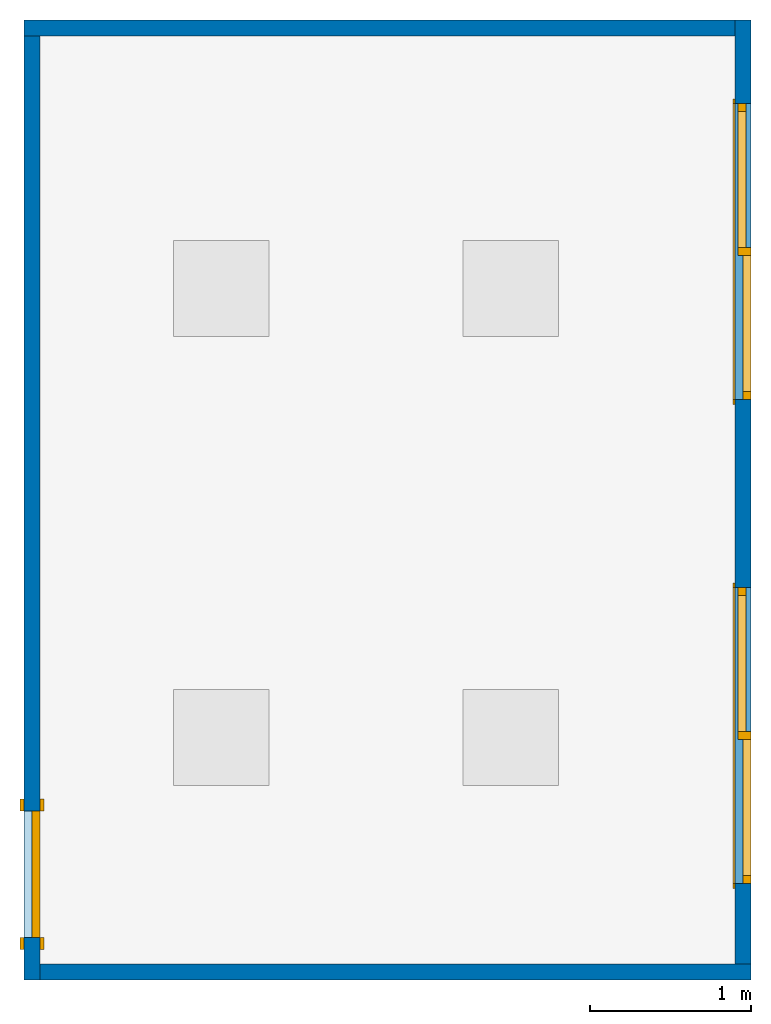
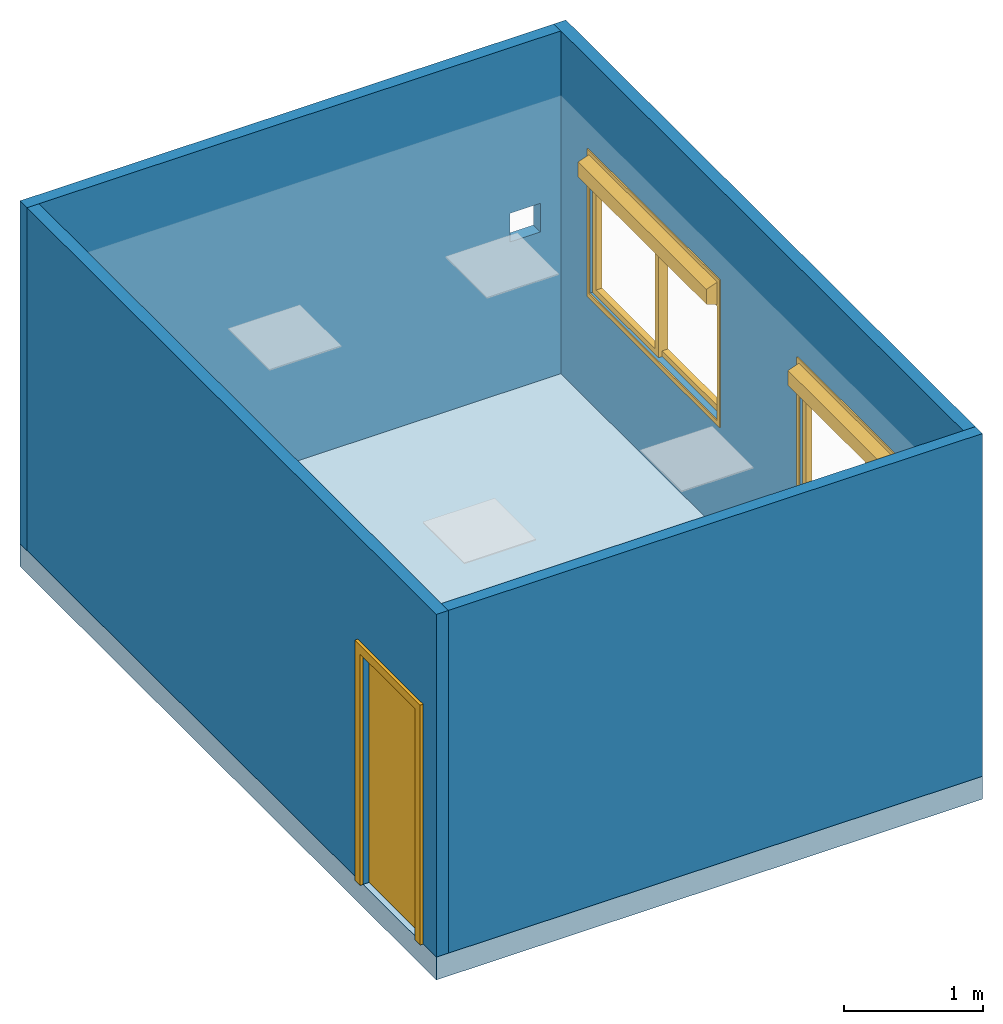
# One storey, part 1 of 3: 4 walls, 2 windows, 1 door, 1 slab, 6 openings.
"""IFC2X3 building model written with IfcOpenShell, lengths in millimetres."""

from ifc_helpers import new_model, entity, si_unit, converted_unit, derived_unit, direction, frame, frame_2d, origin, origin_2d_with_axis, place, context, subcontext, project, spatial, polyline, rectangle, circle, outline, extrude, source, transform, mapped, material, material_list, layer, layer_set, layer_usage, type_object, type_shapes, element, fill, save


model = new_model("IFC2X3")

# Units and contexts
model_context = context("Model", 3, precision=0.01, world=origin(), true_north=direction((6.12303176911189e-17, 1.0)))
body_context = subcontext(model_context, "Body", "Model", "MODEL_VIEW")
ifc_project = project(units=[si_unit("LENGTHUNIT", "METRE", prefix="MILLI"), si_unit("AREAUNIT", "SQUARE_METRE"), si_unit("VOLUMEUNIT", "CUBIC_METRE"), converted_unit("PLANEANGLEUNIT", "DEGREE", entity("IfcRatioMeasure", 0.0174532925199433), si_unit("PLANEANGLEUNIT", "RADIAN"), dimensions=[0, 0, 0, 0, 0, 0, 0]), si_unit("MASSUNIT", "GRAM", prefix="KILO"), derived_unit("MASSDENSITYUNIT", [(si_unit("MASSUNIT", "GRAM", prefix="KILO"), 1), (si_unit("LENGTHUNIT", "METRE"), -3)]), derived_unit("MOMENTOFINERTIAUNIT", [(si_unit("LENGTHUNIT", "METRE"), 4)]), si_unit("TIMEUNIT", "SECOND"), si_unit("FREQUENCYUNIT", "HERTZ"), si_unit("THERMODYNAMICTEMPERATUREUNIT", "DEGREE_CELSIUS"), derived_unit("THERMALTRANSMITTANCEUNIT", [(si_unit("MASSUNIT", "GRAM", prefix="KILO"), 1), (si_unit("THERMODYNAMICTEMPERATUREUNIT", "KELVIN"), -1), (si_unit("TIMEUNIT", "SECOND"), -3)]), derived_unit("VOLUMETRICFLOWRATEUNIT", [(si_unit("LENGTHUNIT", "METRE"), 3), (si_unit("TIMEUNIT", "SECOND"), -1)]), si_unit("ELECTRICCURRENTUNIT", "AMPERE"), si_unit("ELECTRICVOLTAGEUNIT", "VOLT"), si_unit("POWERUNIT", "WATT"), si_unit("FORCEUNIT", "NEWTON", prefix="KILO"), si_unit("ILLUMINANCEUNIT", "LUX"), si_unit("LUMINOUSFLUXUNIT", "LUMEN"), si_unit("LUMINOUSINTENSITYUNIT", "CANDELA"), derived_unit("USERDEFINED", [(si_unit("MASSUNIT", "GRAM", prefix="KILO"), -1), (si_unit("LENGTHUNIT", "METRE"), -2), (si_unit("TIMEUNIT", "SECOND"), 3), (si_unit("LUMINOUSFLUXUNIT", "LUMEN"), 1)]), derived_unit("LINEARVELOCITYUNIT", [(si_unit("LENGTHUNIT", "METRE"), 1), (si_unit("TIMEUNIT", "SECOND"), -1)]), si_unit("PRESSUREUNIT", "PASCAL"), derived_unit("USERDEFINED", [(si_unit("LENGTHUNIT", "METRE"), -2), (si_unit("MASSUNIT", "GRAM", prefix="KILO"), 1), (si_unit("TIMEUNIT", "SECOND"), -2)]), derived_unit("LINEARFORCEUNIT", [(si_unit("MASSUNIT", "GRAM", prefix="KILO"), 1), (si_unit("LENGTHUNIT", "METRE"), 1), (si_unit("TIMEUNIT", "SECOND"), -2), (si_unit("LENGTHUNIT", "METRE"), -1)]), derived_unit("PLANARFORCEUNIT", [(si_unit("MASSUNIT", "GRAM", prefix="KILO"), 1), (si_unit("LENGTHUNIT", "METRE"), 1), (si_unit("TIMEUNIT", "SECOND"), -2), (si_unit("LENGTHUNIT", "METRE"), -2)])], contexts=[model_context])

# Site, building, storey
site_placement = place(None, origin())
site = spatial("IfcSite", under=ifc_project, at=site_placement, CompositionType="ELEMENT")
building_placement = place(site_placement, origin())
building = spatial("IfcBuilding", under=site, at=building_placement, CompositionType="ELEMENT")
storey_placement = place(building_placement, origin())
storey = spatial("IfcBuildingStorey", under=building, at=storey_placement, Name="Niveau 1", CompositionType="ELEMENT", Elevation=0.0)

# Slab, openings
ifc_material_1 = material(Name="Moquette")
ifc_layer_1 = layer(ifc_material_1, 10.0)
ifc_material_2 = material()
ifc_layer_2 = layer(ifc_material_2, 190.0)
ifc_layer_set_1 = layer_set([ifc_layer_1, ifc_layer_2], Name="Sol:STR_19+1cm")
ifc_layer_usage_1 = layer_usage(ifc_layer_set_1, "AXIS3", "POSITIVE", 0.0)
slab_type = type_object("IfcSlabType", Name="Sol:STR_19+1cm", PredefinedType="FLOOR", material=ifc_layer_set_1)
slab_placement = place(storey_placement, origin())
slab = element("IfcSlab", 1, at=slab_placement, inside=storey, type_object=slab_type, material=ifc_layer_usage_1, Name="Sol:STR_19+1cm", ObjectType="Sol:STR_19+1cm", PredefinedType="FLOOR", context=body_context, shape_type="SweptSolid", body=[
    extrude(rectangle(XDim=4520.0, YDim=5970.0, at=origin_2d_with_axis()), frame((-194.560939373683, 872.952575554333, 0.0), z_axis=(0.0, 0.0, -1.0), x_axis=(-1.0, 0.0, 0.0)), (0.0, 0.0, 1.0), 200.0),
])
opening_1_placement = place(slab_placement, origin())
element("IfcOpeningElement", 2, at=opening_1_placement, cuts=slab, ObjectType="Opening", context=body_context, shape_type="SweptSolid", body=[
    extrude(circle(Radius=80.0, at=origin_2d_with_axis()), frame((1675.43906062632, -1292.04742444566, -1524.0), z_axis=(0.0, 0.0, 1.0), x_axis=(-1.0, 0.0, 0.0)), (0.0, 0.0, 1.0), 3048.0),
])
opening_2_placement = place(slab_placement, origin())
element("IfcOpeningElement", 3, at=opening_2_placement, cuts=slab, ObjectType="Opening", context=body_context, shape_type="SweptSolid", body=[
    extrude(rectangle(XDim=300.0, YDim=100.000000000003, at=origin_2d_with_axis()), frame((1675.43906062632, -942.047424445667, -1524.0), z_axis=(0.0, 0.0, 1.0), x_axis=(0.0, 1.0, 0.0)), (0.0, 0.0, 1.0), 3048.0),
])

# Wall, opening
ifc_material_3 = material(Name="Cloison")
ifc_layer_3 = layer(ifc_material_3, 100.0)
ifc_layer_set_2 = layer_set([ifc_layer_3], Name="Mur de base:Cloison 100")
ifc_layer_usage_2 = layer_usage(ifc_layer_set_2, "AXIS2", "NEGATIVE", 50.0)
wall_type = type_object("IfcWallType", Name="Mur de base:Cloison 100", PredefinedType="STANDARD", material=ifc_layer_set_2)
wall_1_placement = place(storey_placement, frame((-2454.56093937368, 3807.95257555433, 0.0)))
wall_1 = element("IfcWallStandardCase", 4, at=wall_1_placement, inside=storey, type_object=wall_type, material=ifc_layer_usage_2, Name="Mur de base:Cloison 100", ObjectType="Mur de base:Cloison 100", context=body_context, shape_type="SweptSolid", body=[
    extrude(rectangle(XDim=4420.0, YDim=100.0, at=frame_2d((2210.0, 0.0), x_axis=(-1.0, 0.0))), origin(), (0.0, 0.0, 1.0), 3000.0),
])
opening_3_placement = place(wall_1_placement, origin())
element("IfcOpeningElement", 5, at=opening_3_placement, cuts=wall_1, Name="Mur de base:Cloison 100", ObjectType="Opening", context=body_context, shape_type="SweptSolid", body=[
    extrude(rectangle(XDim=250.000000000001, YDim=250.0, at=origin_2d_with_axis()), frame((4125.0, -1574.0, 1425.0), z_axis=(0.0, 1.0, 0.0), x_axis=(0.0, 0.0, 1.0)), (0.0, 0.0, 1.0), 3048.0),
])

# Wall, opening, door
ifc_layer_usage_3 = layer_usage(ifc_layer_set_2, "AXIS2", "NEGATIVE", 50.0)
wall_2_placement = place(storey_placement, frame((-2404.56093937368, -2112.04742444567, 0.0), z_axis=(0.0, 0.0, 1.0), x_axis=(0.0, 1.0, 0.0)))
wall_2 = element("IfcWallStandardCase", 6, at=wall_2_placement, inside=storey, type_object=wall_type, material=ifc_layer_usage_3, Name="Mur de base:Cloison 100", ObjectType="Mur de base:Cloison 100", context=body_context, shape_type="SweptSolid", body=[
    extrude(rectangle(XDim=5870.0, YDim=100.0, at=frame_2d((2935.0, 0.0), x_axis=(-1.0, 0.0))), origin(), (0.0, 0.0, 1.0), 3000.0),
])
opening_4_placement = place(wall_2_placement, frame((1050.0, 50.0, 0.0)))
opening_4 = element("IfcOpeningElement", 7, at=opening_4_placement, cuts=wall_2, Name="Simple avec alignement:93x210ht:1", ObjectType="Opening", context=body_context, shape_type="SweptSolid", body=[
    extrude(rectangle(XDim=785.0, YDim=2024.0, at=frame_2d((1012.0, 392.5), x_axis=(0.0, 1.0))), frame((0.0, 0.0, 0.0), z_axis=(0.0, -1.0, 0.0), x_axis=(0.0, 0.0, 1.0)), (0.0, 0.0, 1.0), 100.0),
])
ifc_material_4 = material(Name="Porte - Cadre")
ifc_material_5 = material(Name="Porte - Panneau")
ifc_material_list_1 = material_list([ifc_material_4, ifc_material_5])
ifc_material_list_2 = material_list([ifc_material_4, ifc_material_5])
door_style = type_object("IfcDoorStyle", Name="Simple avec alignement:93x210ht", ConstructionType="NOTDEFINED", OperationType="SINGLE_SWING_RIGHT", ParameterTakesPrecedence=False, Sizeable=False, material=ifc_material_list_2)
shared_shape_1 = source(origin(), body_context, "Body", "SweptSolid", [
    extrude(outline(polyline([(-468.5, -1069.0), (468.5, -1069.0), (468.5, 1031.0), (392.5, 1031.0), (392.5, -993.0), (-392.5, -993.0), (-392.5, 1031.0), (-468.5, 1031.0), (-468.5, -1069.0)])), frame((392.500000000001, 100.0, 1031.0), z_axis=(0.0, 1.0, 0.0), x_axis=(1.0, 0.0, 0.0)), (0.0, 0.0, 1.0), 24.9999999999945),
    extrude(outline(polyline([(-1069.0, -468.499999999997), (1031.0, -468.499999999997), (1031.0, -392.500000000008), (-993.0, -392.500000000008), (-993.0, 392.500000000002), (1031.0, 392.500000000002), (1031.0, 468.500000000003), (-1069.0, 468.500000000003), (-1069.0, -468.499999999997)])), frame((392.500000000003, -25.0, 1031.0), z_axis=(0.0, 1.0, 0.0), x_axis=(0.0, 0.0, -1.0)), (0.0, 0.0, 1.0), 25.0000000000056),
    extrude(rectangle(XDim=51.0, YDim=785.0, at=origin_2d_with_axis()), frame((392.500000000001, 74.5000000000007, 0.0), z_axis=(0.0, 0.0, 1.0), x_axis=(0.0, 1.0, 0.0)), (0.0, 0.0, 1.0), 2024.0),
])
type_shapes(door_style, [shared_shape_1])
door_placement = place(opening_4_placement, frame((0.0, 0.0, 0.0), z_axis=(0.0, 0.0, 1.0), x_axis=(-1.0, 0.0, 0.0)))
door = element("IfcDoor", 8, at=door_placement, inside=storey, type_object=door_style, material=ifc_material_list_1, Name="Simple avec alignement:93x210ht", ObjectType="Simple avec alignement:93x210ht", OverallHeight=2024.0, OverallWidth=785.0, context=body_context, shape_type="MappedRepresentation", body=[
    mapped(shared_shape_1, transform((0.0, 0.0, 0.0), scale=1.0)),
])
fill(opening_4, door)

# Wall
ifc_layer_usage_4 = layer_usage(ifc_layer_set_2, "AXIS2", "NEGATIVE", 50.0)
wall_3_placement = place(storey_placement, frame((2065.43906062632, -2062.04742444567, 0.0), z_axis=(0.0, 0.0, 1.0), x_axis=(-1.0, 0.0, 0.0)))
element("IfcWallStandardCase", 9, at=wall_3_placement, inside=storey, type_object=wall_type, material=ifc_layer_usage_4, Name="Mur de base:Cloison 100", ObjectType="Mur de base:Cloison 100", context=body_context, shape_type="SweptSolid", body=[
    extrude(rectangle(XDim=4420.0, YDim=100.0, at=frame_2d((2210.0, 0.0), x_axis=(-1.0, 0.0))), origin(), (0.0, 0.0, 1.0), 3000.0),
])

# Wall, openings, windows
ifc_layer_usage_5 = layer_usage(ifc_layer_set_2, "AXIS2", "NEGATIVE", 50.0)
wall_4_placement = place(storey_placement, frame((2015.43906062632, 3857.95257555433, 0.0), z_axis=(0.0, 0.0, 1.0), x_axis=(0.0, -1.0, 0.0)))
wall_4 = element("IfcWallStandardCase", 10, at=wall_4_placement, inside=storey, type_object=wall_type, material=ifc_layer_usage_5, Name="Mur de base:Cloison 100", ObjectType="Mur de base:Cloison 100", context=body_context, shape_type="SweptSolid", body=[
    extrude(rectangle(XDim=5870.0, YDim=100.0, at=frame_2d((2935.0, 0.0), x_axis=(-1.0, 0.0))), origin(), (0.0, 0.0, 1.0), 3000.0),
])
opening_5_placement = place(wall_4_placement, frame((520.0, -50.0, 960.0)))
opening_5 = element("IfcOpeningElement", 11, at=opening_5_placement, cuts=wall_4, Name="1", ObjectType="Opening", context=body_context, shape_type="SweptSolid", body=[
    extrude(rectangle(XDim=999.999999999999, YDim=1840.0, at=frame_2d((500.0, 919.999999999999), x_axis=(1.0, 0.0))), frame((0.0, 0.0, 0.0), z_axis=(0.0, 1.0, 0.0), x_axis=(0.0, 0.0, 1.0)), (0.0, 0.0, 1.0), 100.0),
])
opening_6_placement = place(wall_4_placement, frame((3530.0, -50.0, 960.0)))
opening_6 = element("IfcOpeningElement", 12, at=opening_6_placement, cuts=wall_4, Name="1", ObjectType="Opening", context=body_context, shape_type="SweptSolid", body=[
    extrude(rectangle(XDim=999.999999999999, YDim=1840.0, at=frame_2d((500.0, 919.999999999999), x_axis=(1.0, 0.0))), frame((0.0, 0.0, 0.0), z_axis=(0.0, 1.0, 0.0), x_axis=(0.0, 0.0, 1.0)), (0.0, 0.0, 1.0), 100.0),
])
ifc_material_6 = material()
window_style = type_object("IfcWindowStyle", ConstructionType="NOTDEFINED", OperationType="NOTDEFINED", ParameterTakesPrecedence=False, Sizeable=False, material=ifc_material_6)
shared_shape_2 = source(origin(), body_context, "Body", "SweptSolid", [
    extrude(outline(polyline([(-645.0, -950.0), (645.0, -950.0), (645.0, 950.0), (-645.0, 950.0), (-645.0, -950.0)]), holes=[polyline([(-395.0, -920.0), (-395.0, 920.0), (605.0, 920.0), (605.0, -920.0), (-395.0, -920.0)])]), frame((920.0, -10.0, 605.0), z_axis=(0.0, 1.0, 0.0), x_axis=(0.0, 0.0, -1.0)), (0.0, 0.0, 1.0), 10.0),
    extrude(outline(polyline([(-472.5, -500.0), (472.5, -500.0), (472.5, 500.0), (-472.5, 500.0), (-472.5, -500.0)]), holes=[polyline([(422.5, -450.0), (-422.5, -450.0), (-422.5, 450.0), (422.5, 450.0), (422.5, -450.0)])]), frame((1367.5, 50.0, 500.0), z_axis=(0.0, 1.0, 0.0), x_axis=(1.0, 0.0, 0.0)), (0.0, 0.0, 1.0), 50.0),
    extrude(outline(polyline([(-472.5, -500.0), (472.5, -500.0), (472.5, 500.0), (-472.5, 500.0), (-472.5, -500.0)]), holes=[polyline([(422.5, -450.0), (-422.5, -450.0), (-422.5, 450.0), (422.5, 450.0), (422.5, -450.0)])]), frame((472.499999999999, 20.0, 500.0), z_axis=(0.0, 1.0, 0.0), x_axis=(1.0, 0.0, 0.0)), (0.0, 0.0, 1.0), 50.0),
    extrude(outline(polyline([(-97.4999999999992, -45.0), (97.5, -45.0), (64.7426789160414, 45.0), (-64.7426789160411, 45.0), (-97.4999999999992, -45.0)])), frame((0.0, -55.0, 1117.5), z_axis=(1.0, 0.0, 0.0), x_axis=(0.0, 0.0, 1.0)), (0.0, 0.0, 1.0), 1840.0),
])
type_shapes(window_style, [shared_shape_2])
window_1_placement = place(opening_5_placement, origin())
window_1 = element("IfcWindow", 13, at=window_1_placement, inside=storey, type_object=window_style, material=ifc_material_6, OverallHeight=1000.0, OverallWidth=1840.0, context=body_context, shape_type="MappedRepresentation", body=[
    mapped(shared_shape_2, transform((0.0, 0.0, 0.0), scale=1.0)),
])
fill(opening_5, window_1)
window_2_placement = place(opening_6_placement, origin())
window_2 = element("IfcWindow", 14, at=window_2_placement, inside=storey, type_object=window_style, material=ifc_material_6, OverallHeight=1000.0, OverallWidth=1840.0, context=body_context, shape_type="MappedRepresentation", body=[
    mapped(shared_shape_2, transform((0.0, 0.0, 0.0), scale=1.0)),
])
fill(opening_6, window_2)

save(model, "model.ifc")
